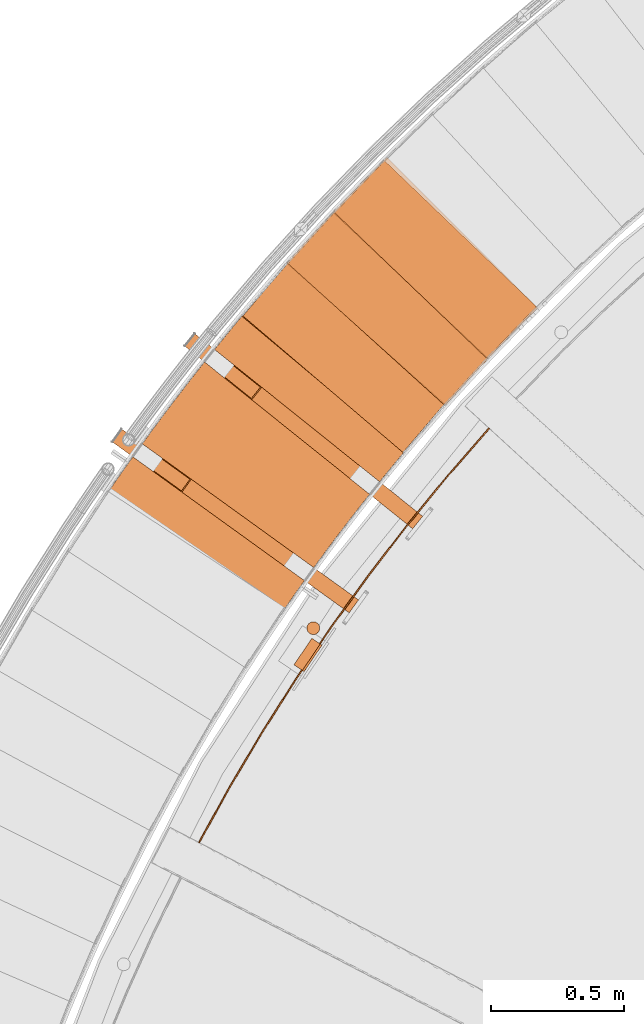
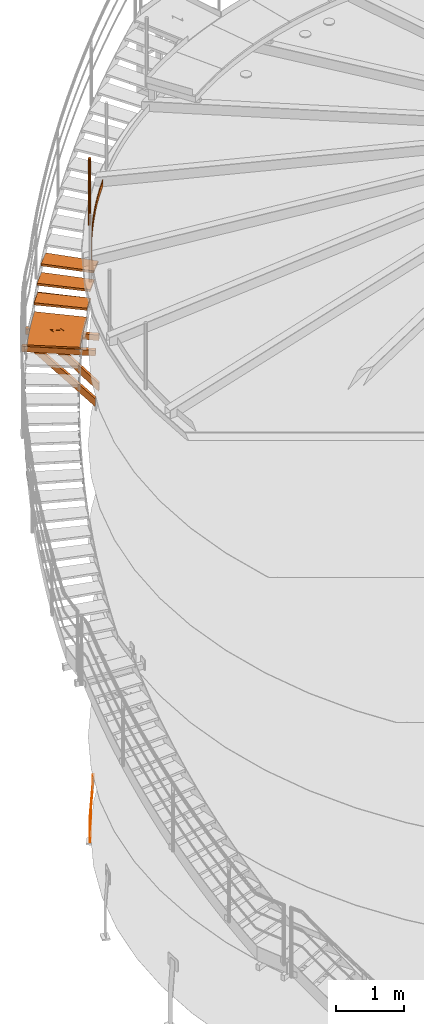
# One storey, part 31 of 126: 14 proxies.
"""IFC2X3 building model written with IfcOpenShell, lengths in millimetres."""

from ifc_helpers import new_model, si_unit, origin, origin_with_axes, place, context, project, spatial, faceted_brep, material, element, save


model = new_model("IFC2X3")

# Units and contexts
context_of_model_1 = context(None, 3, precision=0.1, world=origin())
context_of_model_2 = context(None, 3, precision=0.1, world=origin())
ifc_project = project(units=[si_unit("LENGTHUNIT", "METRE", prefix="MILLI"), si_unit("AREAUNIT", "SQUARE_METRE", prefix="CENTI"), si_unit("VOLUMEUNIT", "CUBIC_METRE", prefix="CENTI"), si_unit("MASSUNIT", "GRAM", prefix="KILO")], contexts=[context_of_model_1, context_of_model_2])

# Site, building, storey
site_placement = place(None, origin_with_axes())
site = spatial("IfcSite", under=ifc_project, at=site_placement, CompositionType="ELEMENT")
building_placement = place(site_placement, origin_with_axes())
building = spatial("IfcBuilding", under=site, at=building_placement, CompositionType="ELEMENT")
storey_placement = place(building_placement, origin_with_axes())
storey = spatial("IfcBuildingStorey", under=building, at=storey_placement, CompositionType="ELEMENT")

# Proxies
ifc_material_1 = material(Name="STAHL")
proxy_1_placement = place(storey_placement, origin_with_axes())
element("IfcBuildingElementProxy", 1, at=proxy_1_placement, inside=storey, material=ifc_material_1, Name="profile", context=context_of_model_2, shape_type="Brep", body=[
    faceted_brep([(1541.3, 12433.1, 651.1), (1539.9, 12431.0, 654.1), (1546.6, 12426.6, 654.1), (1548.0, 12428.6, 651.1), (1542.4, 12434.6, 647.7), (1549.0, 12430.2, 647.7), (1543.0, 12435.6, 643.9), (1549.6, 12431.1, 643.9), (1549.8, 12431.4, 640.0), (1549.8, 12431.4, 540.0), (1518.3, 12452.7, 0.0), (1518.3, 12452.7, -500.0), (1511.7, 12457.2, -500.0), (1511.7, 12457.2, 0.0), (1543.2, 12435.9, 540.0), (1543.2, 12435.9, 640.0), (1484.6, 12334.7, 651.1), (1486.0, 12336.8, 654.1), (1479.4, 12341.3, 654.1), (1478.0, 12339.2, 651.1), (1483.6, 12333.2, 647.7), (1477.0, 12337.7, 647.7), (1483.0, 12332.3, 643.9), (1476.3, 12336.7, 643.9), (1482.7, 12331.9, 540.0), (1482.7, 12331.9, 640.0), (1476.1, 12336.4, 640.0), (1476.1, 12336.4, 540.0), (1444.6, 12357.7, 0.0), (1444.6, 12357.7, -500.0), (1451.2, 12353.2, -500.0), (1451.2, 12353.2, 0.0), (1491.7, 12345.3, 659.6), (1493.9, 12348.5, 660.0), (1538.7, 12414.8, 660.0), (1540.8, 12418.1, 659.6), (1534.2, 12422.6, 659.6), (1532.0, 12419.3, 660.0), (1487.3, 12353.0, 660.0), (1485.1, 12349.8, 659.6), (1489.6, 12342.2, 658.5), (1483.0, 12346.7, 658.5), (1487.7, 12339.3, 656.6), (1481.1, 12343.8, 656.6), (1536.3, 12425.7, 658.5), (1542.9, 12421.2, 658.5), (1538.2, 12428.5, 656.6), (1544.9, 12424.1, 656.6)], [[[0, 1, 2, 3]], [[4, 0, 3, 5]], [[6, 4, 5, 7]], [[7, 8, 9, 10, 11, 12, 13, 14, 15, 6]], [[16, 17, 18, 19]], [[20, 16, 19, 21]], [[22, 20, 21, 23]], [[24, 25, 22, 23, 26, 27, 28, 29, 30, 31]], [[32, 33, 34, 35, 36, 37, 38, 39]], [[40, 32, 39, 41]], [[42, 40, 41, 43]], [[42, 43, 18, 17]], [[44, 36, 35, 45]], [[46, 44, 45, 47]], [[46, 47, 2, 1]], [[27, 26, 23, 21, 19, 18, 43, 41, 39, 38, 37, 36, 44, 46, 1, 0, 4, 6, 15, 14, 13, 12, 29, 28]], [[25, 24, 31, 30, 11, 10, 9, 8, 7, 5, 3, 2, 47, 45, 35, 34, 33, 32, 40, 42, 17, 16, 20, 22]], [[30, 29, 12, 11]]]),
])
proxy_2_placement = place(storey_placement, origin_with_axes())
element("IfcBuildingElementProxy", 2, at=proxy_2_placement, inside=storey, material=ifc_material_1, Name="profile", context=context_of_model_2, shape_type="Brep", body=[
    faceted_brep([(1541.0, 12499.6, 11706.0), (1541.0, 12499.6, 10506.0), (1539.3, 12505.2, 10506.0), (1539.3, 12505.2, 11706.0), (1536.3, 12510.1, 10506.0), (1536.3, 12510.1, 11706.0), (1532.1, 12514.2, 10506.0), (1532.1, 12514.2, 11706.0), (1527.2, 12517.2, 10506.0), (1527.2, 12517.2, 11706.0), (1521.6, 12519.0, 10506.0), (1521.6, 12519.0, 11706.0), (1515.8, 12519.3, 10506.0), (1515.8, 12519.3, 11706.0), (1510.1, 12518.2, 10506.0), (1510.1, 12518.2, 11706.0), (1504.8, 12515.8, 10506.0), (1504.8, 12515.8, 11706.0), (1500.2, 12512.2, 10506.0), (1500.2, 12512.2, 11706.0), (1496.6, 12507.6, 10506.0), (1496.6, 12507.6, 11706.0), (1494.2, 12502.3, 10506.0), (1494.2, 12502.3, 11706.0), (1493.2, 12496.6, 10506.0), (1493.2, 12496.6, 11706.0), (1493.6, 12490.8, 10506.0), (1493.6, 12490.8, 11706.0), (1495.3, 12485.2, 11706.0), (1495.3, 12485.2, 10506.0), (1498.3, 12480.3, 11706.0), (1498.3, 12480.3, 10506.0), (1502.5, 12476.2, 11706.0), (1502.5, 12476.2, 10506.0), (1507.4, 12473.2, 11706.0), (1507.4, 12473.2, 10506.0), (1513.0, 12471.4, 11706.0), (1513.0, 12471.4, 10506.0), (1518.8, 12471.1, 11706.0), (1518.8, 12471.1, 10506.0), (1524.5, 12472.2, 11706.0), (1524.5, 12472.2, 10506.0), (1529.9, 12474.6, 11706.0), (1529.9, 12474.6, 10506.0), (1534.4, 12478.2, 11706.0), (1534.4, 12478.2, 10506.0), (1538.0, 12482.8, 11706.0), (1538.0, 12482.8, 10506.0), (1540.4, 12488.1, 11706.0), (1540.4, 12488.1, 10506.0), (1541.4, 12493.8, 11706.0), (1541.4, 12493.8, 10506.0)], [[[0, 1, 2, 3]], [[3, 2, 4, 5]], [[5, 4, 6, 7]], [[7, 6, 8, 9]], [[9, 8, 10, 11]], [[11, 10, 12, 13]], [[13, 12, 14, 15]], [[15, 14, 16, 17]], [[17, 16, 18, 19]], [[19, 18, 20, 21]], [[21, 20, 22, 23]], [[23, 22, 24, 25]], [[25, 24, 26, 27]], [[28, 27, 26, 29]], [[30, 28, 29, 31]], [[32, 30, 31, 33]], [[34, 32, 33, 35]], [[36, 34, 35, 37]], [[38, 36, 37, 39]], [[40, 38, 39, 41]], [[42, 40, 41, 43]], [[44, 42, 43, 45]], [[46, 44, 45, 47]], [[48, 46, 47, 49]], [[50, 48, 49, 51]], [[0, 50, 51, 1]], [[38, 40, 42, 44, 46, 48, 50, 0, 3, 5, 7, 9, 11, 13, 15, 17, 19, 21, 23, 25, 27, 28, 30, 32, 34, 36]], [[39, 37, 35, 33, 31, 29, 26, 24, 22, 20, 18, 16, 14, 12, 10, 8, 6, 4, 2, 1, 51, 49, 47, 45, 43, 41]]]),
])
proxy_3_placement = place(storey_placement, origin_with_axes())
element("IfcBuildingElementProxy", 3, at=proxy_3_placement, inside=storey, material=ifc_material_1, Name="profile", context=context_of_model_2, shape_type="Brep", body=[
    faceted_brep([(1086.2, 11691.9, 10516.0), (1086.2, 11691.9, 10636.0), (1201.2, 11900.1, 10636.0), (1322.5, 12104.8, 10636.0), (1450.0, 12305.6, 10636.0), (1583.5, 12502.6, 10636.0), (1723.0, 12695.3, 10636.0), (1868.2, 12883.8, 10636.0), (2019.1, 13067.8, 10636.0), (2175.4, 13247.1, 10636.0), (2175.4, 13247.1, 10516.0), (2019.1, 13067.8, 10516.0), (1868.2, 12883.8, 10516.0), (1723.0, 12695.3, 10516.0), (1583.5, 12502.6, 10516.0), (1450.0, 12305.6, 10516.0), (1322.5, 12104.8, 10516.0), (1201.2, 11900.1, 10516.0), (1090.6, 11689.5, 10636.0), (1205.6, 11897.6, 10636.0), (1326.8, 12102.1, 10636.0), (1454.2, 12302.9, 10636.0), (1587.6, 12499.7, 10636.0), (1727.0, 12692.4, 10636.0), (1872.1, 12880.7, 10636.0), (2022.9, 13064.5, 10636.0), (2179.2, 13243.7, 10636.0), (1090.6, 11689.5, 10516.0), (1205.6, 11897.6, 10516.0), (1326.8, 12102.1, 10516.0), (1454.2, 12302.9, 10516.0), (1587.6, 12499.7, 10516.0), (1727.0, 12692.4, 10516.0), (1872.1, 12880.7, 10516.0), (2022.9, 13064.5, 10516.0), (2179.2, 13243.7, 10516.0)], [[[0, 1, 2, 3, 4, 5, 6, 7, 8, 9, 10, 11, 12, 13, 14, 15, 16, 17]], [[18, 19, 20, 21, 22, 23, 24, 25, 26, 9, 8, 7, 6, 5, 4, 3, 2, 1]], [[18, 27, 28, 29, 30, 31, 32, 33, 34, 35, 26, 25, 24, 23, 22, 21, 20, 19]], [[27, 0, 17, 16, 15, 14, 13, 12, 11, 10, 35, 34, 33, 32, 31, 30, 29, 28]], [[18, 1, 0, 27]], [[26, 35, 10, 9]]]),
])
ifc_material_2 = material(Name="HOLZ")
proxy_4_placement = place(storey_placement, origin_with_axes())
element("IfcBuildingElementProxy", 4, at=proxy_4_placement, inside=storey, material=ifc_material_2, context=context_of_model_2, shape_type="Brep", body=[
    faceted_brep([(1436.4084, 13886.589, 8487.1062), (1418.8783, 13866.953, 8487.1062), (1401.4068, 13847.264, 8487.1062), (1383.9943, 13827.523, 8487.1062), (1366.6407, 13807.73, 8487.1062), (1349.3464, 13787.885, 8487.1062), (1332.1113, 13767.989, 8487.1062), (1314.9357, 13748.042, 8487.1062), (1297.8198, 13728.043, 8487.1062), (1280.7636, 13707.993, 8487.1062), (1263.7674, 13687.893, 8487.1062), (1246.8312, 13667.742, 8487.1062), (1860.0256, 13153.94, 8487.1062), (1877.1435, 13174.3, 8487.1062), (1894.3289, 13194.604, 8487.1062), (1911.5816, 13214.85, 8487.1062), (1928.9013, 13235.04, 8487.1062), (1946.2879, 13255.171, 8487.1062), (1963.7413, 13275.245, 8487.1062), (1981.2611, 13295.261, 8487.1062), (1998.8473, 13315.218, 8487.1062), (2016.4996, 13335.117, 8487.1062), (2034.2178, 13354.958, 8487.1062), (1436.4084, 13886.589, 8447.1062), (2034.2178, 13354.958, 8447.1062), (2016.4996, 13335.117, 8447.1062), (1998.8473, 13315.218, 8447.1062), (1981.2611, 13295.261, 8447.1062), (1963.7413, 13275.245, 8447.1062), (1946.2879, 13255.171, 8447.1062), (1928.9013, 13235.04, 8447.1062), (1911.5816, 13214.85, 8447.1062), (1894.3289, 13194.604, 8447.1062), (1877.1435, 13174.3, 8447.1062), (1860.0256, 13153.94, 8447.1062), (1246.8312, 13667.742, 8447.1062), (1263.7674, 13687.893, 8447.1062), (1280.7636, 13707.993, 8447.1062), (1297.8198, 13728.043, 8447.1062), (1314.9357, 13748.042, 8447.1062), (1332.1113, 13767.989, 8447.1062), (1349.3464, 13787.885, 8447.1062), (1366.6407, 13807.73, 8447.1062), (1383.9943, 13827.523, 8447.1062), (1401.4068, 13847.264, 8447.1062), (1418.8783, 13866.953, 8447.1062)], [[[0, 1, 2, 3, 4, 5, 6, 7, 8, 9, 10, 11, 12, 13, 14, 15, 16, 17, 18, 19, 20, 21, 22]], [[23, 24, 25, 26, 27, 28, 29, 30, 31, 32, 33, 34, 35, 36, 37, 38, 39, 40, 41, 42, 43, 44, 45]], [[0, 23, 45, 1]], [[1, 45, 44, 2]], [[2, 44, 43, 3]], [[3, 43, 42, 4]], [[4, 42, 41, 5]], [[5, 41, 40, 6]], [[6, 40, 39, 7]], [[7, 39, 38, 8]], [[8, 38, 37, 9]], [[9, 37, 36, 10]], [[10, 36, 35, 11]], [[11, 35, 34, 12]], [[12, 34, 33, 13]], [[13, 33, 32, 14]], [[14, 32, 31, 15]], [[15, 31, 30, 16]], [[16, 30, 29, 17]], [[17, 29, 28, 18]], [[18, 28, 27, 19]], [[19, 27, 26, 20]], [[20, 26, 25, 21]], [[21, 25, 24, 22]], [[22, 24, 23, 0]]]),
])
proxy_5_placement = place(storey_placement, origin_with_axes())
element("IfcBuildingElementProxy", 5, at=proxy_5_placement, inside=storey, material=ifc_material_2, context=context_of_model_2, shape_type="Brep", body=[
    faceted_brep([(1612.3707, 14077.378, 8660.3125), (1594.2702, 14058.266, 8660.3125), (1576.2268, 14039.1, 8660.3125), (1558.2408, 14019.88, 8660.3125), (1540.3122, 14000.607, 8660.3125), (1522.4412, 13981.28, 8660.3125), (1504.628, 13961.9, 8660.3125), (1486.8727, 13942.466, 8660.3125), (1469.1756, 13922.98, 8660.3125), (1451.5366, 13903.441, 8660.3125), (1433.9561, 13883.85, 8660.3125), (1416.4342, 13864.206, 8660.3125), (2014.2398, 13332.577, 8660.3125), (2031.9496, 13352.425, 8660.3125), (2049.7252, 13372.214, 8660.3125), (2067.5663, 13391.944, 8660.3125), (2085.4728, 13411.615, 8660.3125), (2103.4444, 13431.226, 8660.3125), (2121.4811, 13450.778, 8660.3125), (2139.5825, 13470.269, 8660.3125), (2157.7484, 13489.7, 8660.3125), (2175.9788, 13509.071, 8660.3125), (2194.2733, 13528.382, 8660.3125), (1612.3707, 14077.378, 8620.3125), (2194.2733, 13528.382, 8620.3125), (2175.9788, 13509.071, 8620.3125), (2157.7484, 13489.7, 8620.3125), (2139.5825, 13470.269, 8620.3125), (2121.4811, 13450.778, 8620.3125), (2103.4444, 13431.226, 8620.3125), (2085.4728, 13411.615, 8620.3125), (2067.5663, 13391.944, 8620.3125), (2049.7252, 13372.214, 8620.3125), (2031.9496, 13352.425, 8620.3125), (2014.2398, 13332.577, 8620.3125), (1416.4342, 13864.206, 8620.3125), (1433.9561, 13883.85, 8620.3125), (1451.5366, 13903.441, 8620.3125), (1469.1756, 13922.98, 8620.3125), (1486.8727, 13942.466, 8620.3125), (1504.628, 13961.9, 8620.3125), (1522.4412, 13981.28, 8620.3125), (1540.3122, 14000.607, 8620.3125), (1558.2408, 14019.88, 8620.3125), (1576.2268, 14039.1, 8620.3125), (1594.2702, 14058.266, 8620.3125)], [[[0, 1, 2, 3, 4, 5, 6, 7, 8, 9, 10, 11, 12, 13, 14, 15, 16, 17, 18, 19, 20, 21, 22]], [[23, 24, 25, 26, 27, 28, 29, 30, 31, 32, 33, 34, 35, 36, 37, 38, 39, 40, 41, 42, 43, 44, 45]], [[0, 23, 45, 1]], [[1, 45, 44, 2]], [[2, 44, 43, 3]], [[3, 43, 42, 4]], [[4, 42, 41, 5]], [[5, 41, 40, 6]], [[6, 40, 39, 7]], [[7, 39, 38, 8]], [[8, 38, 37, 9]], [[9, 37, 36, 10]], [[10, 36, 35, 11]], [[11, 35, 34, 12]], [[12, 34, 33, 13]], [[13, 33, 32, 14]], [[14, 32, 31, 15]], [[15, 31, 30, 16]], [[16, 30, 29, 17]], [[17, 29, 28, 18]], [[18, 28, 27, 19]], [[19, 27, 26, 20]], [[20, 26, 25, 21]], [[21, 25, 24, 22]], [[22, 24, 23, 0]]]),
])
proxy_6_placement = place(storey_placement, origin_with_axes())
element("IfcBuildingElementProxy", 6, at=proxy_6_placement, inside=storey, material=ifc_material_2, context=context_of_model_2, shape_type="Brep", body=[
    faceted_brep([(1793.8724, 14262.906, 8833.5187), (1775.2172, 14244.334, 8833.5187), (1756.6175, 14225.708, 8833.5187), (1738.0735, 14207.026, 8833.5187), (1719.5854, 14188.288, 8833.5187), (1701.1533, 14169.496, 8833.5187), (1682.7774, 14150.648, 8833.5187), (1664.4578, 14131.746, 8833.5187), (1646.1948, 14112.789, 8833.5187), (1627.9884, 14093.778, 8833.5187), (1609.8389, 14074.712, 8833.5187), (1591.7464, 14055.592, 8833.5187), (2173.6452, 13506.599, 8833.5187), (2191.9316, 13525.917, 8833.5187), (2210.2819, 13545.174, 8833.5187), (2228.696, 13564.371, 8833.5187), (2247.1737, 13583.506, 8833.5187), (2265.7148, 13602.579, 8833.5187), (2284.3191, 13621.591, 8833.5187), (2302.9863, 13640.541, 8833.5187), (2321.7163, 13659.43, 8833.5187), (2340.5089, 13678.256, 8833.5187), (2359.3639, 13697.019, 8833.5187), (1793.8724, 14262.906, 8793.5187), (2359.3639, 13697.019, 8793.5187), (2340.5089, 13678.256, 8793.5187), (2321.7163, 13659.43, 8793.5187), (2302.9863, 13640.541, 8793.5187), (2284.3191, 13621.591, 8793.5187), (2265.7148, 13602.579, 8793.5187), (2247.1737, 13583.506, 8793.5187), (2228.696, 13564.371, 8793.5187), (2210.2819, 13545.174, 8793.5187), (2191.9316, 13525.917, 8793.5187), (2173.6452, 13506.599, 8793.5187), (1591.7464, 14055.592, 8793.5187), (1609.8389, 14074.712, 8793.5187), (1627.9884, 14093.778, 8793.5187), (1646.1948, 14112.789, 8793.5187), (1664.4578, 14131.746, 8793.5187), (1682.7774, 14150.648, 8793.5187), (1701.1533, 14169.496, 8793.5187), (1719.5854, 14188.288, 8793.5187), (1738.0735, 14207.026, 8793.5187), (1756.6175, 14225.708, 8793.5187), (1775.2172, 14244.334, 8793.5187)], [[[0, 1, 2, 3, 4, 5, 6, 7, 8, 9, 10, 11, 12, 13, 14, 15, 16, 17, 18, 19, 20, 21, 22]], [[23, 24, 25, 26, 27, 28, 29, 30, 31, 32, 33, 34, 35, 36, 37, 38, 39, 40, 41, 42, 43, 44, 45]], [[0, 23, 45, 1]], [[1, 45, 44, 2]], [[2, 44, 43, 3]], [[3, 43, 42, 4]], [[4, 42, 41, 5]], [[5, 41, 40, 6]], [[6, 40, 39, 7]], [[7, 39, 38, 8]], [[8, 38, 37, 9]], [[9, 37, 36, 10]], [[10, 36, 35, 11]], [[11, 35, 34, 12]], [[12, 34, 33, 13]], [[13, 33, 32, 14]], [[14, 32, 31, 15]], [[15, 31, 30, 16]], [[16, 30, 29, 17]], [[17, 29, 28, 18]], [[18, 28, 27, 19]], [[19, 27, 26, 20]], [[20, 26, 25, 21]], [[21, 25, 24, 22]], [[22, 24, 23, 0]]]),
])
ifc_material_3 = material(Name="S235JRG2")
proxy_7_placement = place(storey_placement, origin_with_axes())
element("IfcBuildingElementProxy", 7, at=proxy_7_placement, inside=storey, material=ifc_material_3, context=context_of_model_2, shape_type="Brep", body=[
    faceted_brep([(1252.8887, 13667.163, 8447.11), (1252.8887, 13667.163, 8487.11), (1428.0963, 13872.595, 8487.11), (1428.0963, 13872.595, 8447.11), (1853.9676, 13154.518, 8447.11), (2029.1751, 13359.95, 8447.11), (2029.1751, 13359.95, 8487.11), (1853.9676, 13154.518, 8487.11)], [[[0, 1, 2, 3]], [[4, 5, 6, 7]], [[0, 4, 7, 1]], [[1, 7, 6, 2]], [[2, 6, 5, 3]], [[3, 5, 4, 0]]]),
])
proxy_8_placement = place(storey_placement, origin_with_axes())
element("IfcBuildingElementProxy", 8, at=proxy_8_placement, inside=storey, material=ifc_material_3, context=context_of_model_2, shape_type="Brep", body=[
    faceted_brep([(1422.4715, 13863.448, 8620.27), (1422.4715, 13863.448, 8660.27), (1603.6497, 14063.634, 8660.27), (1603.6497, 14063.634, 8620.27), (2008.201, 13333.334, 8620.27), (2189.3793, 13533.52, 8620.27), (2189.3793, 13533.52, 8660.27), (2008.201, 13333.334, 8660.27)], [[[0, 1, 2, 3]], [[4, 5, 6, 7]], [[0, 4, 7, 1]], [[1, 7, 6, 2]], [[2, 6, 5, 3]], [[3, 5, 4, 0]]]),
])
proxy_9_placement = place(storey_placement, origin_with_axes())
element("IfcBuildingElementProxy", 9, at=proxy_9_placement, inside=storey, material=ifc_material_3, context=context_of_model_2, shape_type="Brep", body=[
    faceted_brep([(1597.7582, 14054.657, 8793.43), (1597.7582, 14054.657, 8833.43), (1784.7501, 14249.423, 8833.43), (1784.7501, 14249.423, 8793.43), (2167.6308, 13507.532, 8793.43), (2354.6227, 13702.299, 8793.43), (2354.6227, 13702.299, 8833.43), (2167.6308, 13507.532, 8833.43)], [[[0, 1, 2, 3]], [[4, 5, 6, 7]], [[0, 4, 7, 1]], [[1, 7, 6, 2]], [[2, 6, 5, 3]], [[3, 5, 4, 0]]]),
])
proxy_10_placement = place(storey_placement, origin_with_axes())
element("IfcBuildingElementProxy", 10, at=proxy_10_placement, inside=storey, material=ifc_material_3, context=context_of_model_2, shape_type="Brep", body=[
    faceted_brep([(764.1183, 13193.175, 8063.85), (764.1183, 13193.175, 8163.85), (799.2285, 13241.83, 8163.85), (799.2285, 13241.83, 8063.85), (765.8738, 13195.608, 8066.85), (797.4729, 13239.397, 8066.85), (797.4729, 13239.397, 8160.85), (765.8738, 13195.608, 8160.85), (1686.9102, 12601.26, 8063.85), (1651.8001, 12552.606, 8063.85), (1686.9102, 12601.26, 8163.85), (1651.8001, 12552.606, 8163.85), (1653.5556, 12555.039, 8160.85), (1653.5556, 12555.039, 8066.85), (1685.1547, 12598.828, 8160.85), (1685.1547, 12598.828, 8066.85)], [[[0, 1, 2, 3], [4, 5, 6, 7]], [[0, 3, 8, 9]], [[2, 10, 8, 3]], [[1, 11, 10, 2]], [[0, 9, 11, 1]], [[4, 7, 12, 13]], [[6, 14, 12, 7]], [[5, 15, 14, 6]], [[4, 13, 15, 5]], [[9, 8, 10, 11], [12, 14, 15, 13]]]),
])
proxy_11_placement = place(storey_placement, origin_with_axes())
element("IfcBuildingElementProxy", 11, at=proxy_11_placement, inside=storey, material=ifc_material_3, context=context_of_model_2, shape_type="Brep", body=[
    faceted_brep([(1035.8763, 13552.869, 8063.85), (1035.8763, 13552.869, 8163.85), (1073.4031, 13599.685, 8163.85), (1073.4031, 13599.685, 8063.85), (1037.7526, 13555.21, 8066.85), (1071.5268, 13597.344, 8066.85), (1071.5268, 13597.344, 8160.85), (1037.7526, 13555.21, 8160.85), (1927.5399, 12915.025, 8063.85), (1890.013, 12868.209, 8063.85), (1927.5399, 12915.025, 8163.85), (1890.013, 12868.209, 8163.85), (1891.8893, 12870.55, 8160.85), (1891.8893, 12870.55, 8066.85), (1925.6635, 12912.684, 8160.85), (1925.6635, 12912.684, 8066.85)], [[[0, 1, 2, 3], [4, 5, 6, 7]], [[0, 3, 8, 9]], [[2, 10, 8, 3]], [[1, 11, 10, 2]], [[0, 9, 11, 1]], [[4, 7, 12, 13]], [[6, 14, 12, 7]], [[5, 15, 14, 6]], [[4, 13, 15, 5]], [[9, 8, 10, 11], [12, 14, 15, 13]]]),
])
proxy_12_placement = place(storey_placement, origin_with_axes())
element("IfcBuildingElementProxy", 12, at=proxy_12_placement, inside=storey, material=ifc_material_3, context=context_of_model_2, shape_type="Brep", body=[
    faceted_brep([(1175.7698, 13440.733, 8063.85), (1213.2966, 13487.549, 8063.85), (1927.5399, 12915.025, 7148.4665), (1890.013, 12868.209, 7148.4665), (1323.643, 13399.097, 8063.85), (1927.5399, 12915.025, 7289.8879), (1286.1161, 13352.281, 8063.85), (1890.013, 12868.209, 7289.8879), (1180.9565, 13440.42, 8063.85), (1284.6821, 13357.276, 8063.85), (1891.8894, 12870.55, 7285.6452), (1891.8894, 12870.55, 7152.7091), (1318.4562, 13399.41, 8063.85), (1925.6635, 12912.684, 7285.6452), (1214.7306, 13482.554, 8063.85), (1925.6635, 12912.684, 7152.7091)], [[[0, 1, 2, 3]], [[1, 4, 5, 2]], [[4, 6, 7, 5]], [[0, 3, 7, 6]], [[8, 9, 10, 11]], [[9, 12, 13, 10]], [[12, 14, 15, 13]], [[8, 11, 15, 14]], [[1, 0, 6, 4], [8, 14, 12, 9]], [[3, 2, 5, 7], [10, 13, 15, 11]]]),
])
proxy_13_placement = place(storey_placement, origin_with_axes())
element("IfcBuildingElementProxy", 13, at=proxy_13_placement, inside=storey, material=ifc_material_3, Name="BLECH", context=context_of_model_2, shape_type="Brep", body=[
    faceted_brep([(740.2786, 12996.034, 8283.85), (745.1764, 13003.163, 8283.85), (755.0003, 13017.402, 8283.85), (764.8521, 13031.622, 8283.85), (774.7317, 13045.822, 8283.85), (784.6393, 13060.003, 8283.85), (794.5745, 13074.165, 8283.85), (804.5375, 13088.307, 8283.85), (814.5285, 13102.429, 8283.85), (824.5469, 13116.532, 8283.85), (834.593, 13130.615, 8283.85), (844.6668, 13144.679, 8283.85), (854.768, 13158.722, 8283.85), (864.897, 13172.746, 8283.85), (875.0534, 13186.75, 8283.85), (885.2373, 13200.733, 8283.85), (895.4486, 13214.697, 8283.85), (905.6872, 13228.641, 8283.85), (915.9534, 13242.565, 8283.85), (926.2467, 13256.468, 8283.85), (936.5674, 13270.351, 8283.85), (946.9153, 13284.214, 8283.85), (957.2903, 13298.057, 8283.85), (967.6925, 13311.879, 8283.85), (978.1218, 13325.681, 8283.85), (988.578, 13339.462, 8283.85), (999.0616, 13353.223, 8283.85), (1009.5718, 13366.963, 8283.85), (1020.1091, 13380.682, 8283.85), (1030.6733, 13394.381, 8283.85), (1041.2644, 13408.059, 8283.85), (1051.8823, 13421.716, 8283.85), (1062.5271, 13435.353, 8283.85), (1073.1985, 13448.968, 8283.85), (1083.8967, 13462.562, 8283.85), (1094.6215, 13476.136, 8283.85), (1105.3728, 13489.688, 8283.85), (1116.151, 13503.219, 8283.85), (1126.9555, 13516.729, 8283.85), (1137.7865, 13530.218, 8283.85), (1148.6441, 13543.686, 8283.85), (1159.528, 13557.132, 8283.85), (1170.4381, 13570.557, 8283.85), (1181.3749, 13583.96, 8283.85), (1192.3375, 13597.342, 8283.85), (1203.3268, 13610.702, 8283.85), (1214.3423, 13624.041, 8283.85), (1225.3837, 13637.358, 8283.85), (1236.4512, 13650.653, 8283.85), (1247.5448, 13663.927, 8283.85), (1258.6645, 13677.179, 8283.85), (1264.2376, 13683.794, 8283.85), (1868.3535, 13168.51, 8283.85), (1863.3174, 13162.525, 8283.85), (1853.2689, 13150.535, 8283.85), (1843.2435, 13138.526, 8283.85), (1833.2418, 13126.497, 8283.85), (1823.2633, 13114.449, 8283.85), (1813.3087, 13102.382, 8283.85), (1803.3773, 13090.294, 8283.85), (1793.4697, 13078.188, 8283.85), (1783.5857, 13066.062, 8283.85), (1773.7255, 13053.917, 8283.85), (1763.8887, 13041.753, 8283.85), (1754.0759, 13029.57, 8283.85), (1744.2868, 13017.368, 8283.85), (1734.5215, 13005.146, 8283.85), (1724.7801, 12992.906, 8283.85), (1715.0626, 12980.646, 8283.85), (1705.369, 12968.368, 8283.85), (1695.6994, 12956.07, 8283.85), (1686.0536, 12943.754, 8283.85), (1676.4321, 12931.419, 8283.85), (1666.8346, 12919.066, 8283.85), (1657.2612, 12906.693, 8283.85), (1647.712, 12894.302, 8283.85), (1638.1869, 12881.892, 8283.85), (1628.6861, 12869.464, 8283.85), (1619.2096, 12857.018, 8283.85), (1609.7574, 12844.553, 8283.85), (1600.3295, 12832.069, 8283.85), (1590.9259, 12819.567, 8283.85), (1581.5467, 12807.047, 8283.85), (1572.192, 12794.508, 8283.85), (1562.8617, 12781.951, 8283.85), (1553.556, 12769.377, 8283.85), (1544.2748, 12756.784, 8283.85), (1535.0183, 12744.172, 8283.85), (1525.7861, 12731.543, 8283.85), (1516.5787, 12718.896, 8283.85), (1507.3963, 12706.231, 8283.85), (1498.2384, 12693.548, 8283.85), (1489.1051, 12680.847, 8283.85), (1479.9967, 12668.129, 8283.85), (1470.9132, 12655.392, 8283.85), (1461.8546, 12642.638, 8283.85), (1452.8206, 12629.866, 8283.85), (1443.8117, 12617.077, 8283.85), (1434.828, 12604.27, 8283.85), (1425.8688, 12591.446, 8283.85), (1416.9351, 12578.604, 8283.85), (1408.0263, 12565.745, 8283.85), (1399.1427, 12552.869, 8283.85), (1394.7133, 12546.422, 8283.85), (740.2786, 12996.034, 8313.85), (1394.7133, 12546.422, 8313.85), (1399.1427, 12552.869, 8313.85), (1408.0263, 12565.745, 8313.85), (1416.9351, 12578.604, 8313.85), (1425.8688, 12591.446, 8313.85), (1434.828, 12604.27, 8313.85), (1443.8117, 12617.077, 8313.85), (1452.8206, 12629.866, 8313.85), (1461.8546, 12642.638, 8313.85), (1470.9132, 12655.392, 8313.85), (1479.9967, 12668.129, 8313.85), (1489.1051, 12680.847, 8313.85), (1498.2384, 12693.548, 8313.85), (1507.3963, 12706.231, 8313.85), (1516.5787, 12718.896, 8313.85), (1525.7861, 12731.543, 8313.85), (1535.0183, 12744.172, 8313.85), (1544.2748, 12756.784, 8313.85), (1553.556, 12769.377, 8313.85), (1562.8617, 12781.951, 8313.85), (1572.192, 12794.508, 8313.85), (1581.5467, 12807.047, 8313.85), (1590.9259, 12819.567, 8313.85), (1600.3295, 12832.069, 8313.85), (1609.7574, 12844.553, 8313.85), (1619.2096, 12857.018, 8313.85), (1628.6861, 12869.464, 8313.85), (1638.1869, 12881.892, 8313.85), (1647.712, 12894.302, 8313.85), (1657.2612, 12906.693, 8313.85), (1666.8346, 12919.066, 8313.85), (1676.4321, 12931.419, 8313.85), (1686.0536, 12943.754, 8313.85), (1695.6994, 12956.07, 8313.85), (1705.369, 12968.368, 8313.85), (1715.0626, 12980.646, 8313.85), (1724.7801, 12992.906, 8313.85), (1734.5215, 13005.146, 8313.85), (1744.2868, 13017.368, 8313.85), (1754.0759, 13029.57, 8313.85), (1763.8887, 13041.753, 8313.85), (1773.7255, 13053.917, 8313.85), (1783.5857, 13066.062, 8313.85), (1793.4697, 13078.188, 8313.85), (1803.3773, 13090.294, 8313.85), (1813.3087, 13102.382, 8313.85), (1823.2633, 13114.449, 8313.85), (1833.2418, 13126.497, 8313.85), (1843.2435, 13138.526, 8313.85), (1853.2689, 13150.535, 8313.85), (1863.3174, 13162.525, 8313.85), (1868.3535, 13168.51, 8313.85), (1264.2376, 13683.794, 8313.85), (1258.6645, 13677.179, 8313.85), (1247.5448, 13663.927, 8313.85), (1236.4512, 13650.653, 8313.85), (1225.3837, 13637.358, 8313.85), (1214.3423, 13624.041, 8313.85), (1203.3268, 13610.702, 8313.85), (1192.3375, 13597.342, 8313.85), (1181.3749, 13583.96, 8313.85), (1170.4381, 13570.557, 8313.85), (1159.528, 13557.132, 8313.85), (1148.6441, 13543.686, 8313.85), (1137.7865, 13530.218, 8313.85), (1126.9555, 13516.729, 8313.85), (1116.151, 13503.219, 8313.85), (1105.3728, 13489.688, 8313.85), (1094.6215, 13476.136, 8313.85), (1083.8967, 13462.562, 8313.85), (1073.1985, 13448.968, 8313.85), (1062.5271, 13435.353, 8313.85), (1051.8823, 13421.716, 8313.85), (1041.2644, 13408.059, 8313.85), (1030.6733, 13394.381, 8313.85), (1020.1091, 13380.682, 8313.85), (1009.5718, 13366.963, 8313.85), (999.0616, 13353.223, 8313.85), (988.578, 13339.462, 8313.85), (978.1218, 13325.681, 8313.85), (967.6925, 13311.879, 8313.85), (957.2903, 13298.057, 8313.85), (946.9153, 13284.214, 8313.85), (936.5674, 13270.351, 8313.85), (926.2467, 13256.468, 8313.85), (915.9534, 13242.565, 8313.85), (905.6872, 13228.641, 8313.85), (895.4486, 13214.697, 8313.85), (885.2373, 13200.733, 8313.85), (875.0534, 13186.75, 8313.85), (864.897, 13172.746, 8313.85), (854.768, 13158.722, 8313.85), (844.6668, 13144.679, 8313.85), (834.593, 13130.615, 8313.85), (824.5469, 13116.532, 8313.85), (814.5285, 13102.429, 8313.85), (804.5375, 13088.307, 8313.85), (794.5745, 13074.165, 8313.85), (784.6393, 13060.003, 8313.85), (774.7317, 13045.822, 8313.85), (764.8521, 13031.622, 8313.85), (755.0003, 13017.402, 8313.85), (745.1764, 13003.163, 8313.85), (1376.5204, 13112.251, 8313.85), (1383.403, 13113.528, 8313.85), (1398.1378, 13034.103, 8313.85), (1239.0106, 13155.258, 8313.85), (1250.4368, 13093.668, 8313.85), (1243.5543, 13092.391, 8313.85), (1228.8195, 13171.816, 8313.85), (1387.9467, 13050.661, 8313.85), (1376.5204, 13112.251, 8308.85), (1383.403, 13113.528, 8308.85), (1387.9467, 13050.661, 8308.85), (1398.1378, 13034.103, 8308.85), (1228.8195, 13171.816, 8308.85), (1239.0106, 13155.258, 8308.85), (1243.5543, 13092.391, 8308.85), (1250.4368, 13093.668, 8308.85)], [[[0, 1, 2, 3, 4, 5, 6, 7, 8, 9, 10, 11, 12, 13, 14, 15, 16, 17, 18, 19, 20, 21, 22, 23, 24, 25, 26, 27, 28, 29, 30, 31, 32, 33, 34, 35, 36, 37, 38, 39, 40, 41, 42, 43, 44, 45, 46, 47, 48, 49, 50, 51, 52, 53, 54, 55, 56, 57, 58, 59, 60, 61, 62, 63, 64, 65, 66, 67, 68, 69, 70, 71, 72, 73, 74, 75, 76, 77, 78, 79, 80, 81, 82, 83, 84, 85, 86, 87, 88, 89, 90, 91, 92, 93, 94, 95, 96, 97, 98, 99, 100, 101, 102, 103]], [[104, 105, 106, 107, 108, 109, 110, 111, 112, 113, 114, 115, 116, 117, 118, 119, 120, 121, 122, 123, 124, 125, 126, 127, 128, 129, 130, 131, 132, 133, 134, 135, 136, 137, 138, 139, 140, 141, 142, 143, 144, 145, 146, 147, 148, 149, 150, 151, 152, 153, 154, 155, 156, 157, 158, 159, 160, 161, 162, 163, 164, 165, 166, 167, 168, 169, 170, 171, 172, 173, 174, 175, 176, 177, 178, 179, 180, 181, 182, 183, 184, 185, 186, 187, 188, 189, 190, 191, 192, 193, 194, 195, 196, 197, 198, 199, 200, 201, 202, 203, 204, 205, 206, 207], [208, 209, 210, 211, 212, 213, 214, 215]], [[0, 104, 207, 1]], [[1, 207, 206, 2]], [[2, 206, 205, 3]], [[3, 205, 204, 4]], [[4, 204, 203, 5]], [[5, 203, 202, 6]], [[6, 202, 201, 7]], [[7, 201, 200, 8]], [[8, 200, 199, 9]], [[9, 199, 198, 10]], [[10, 198, 197, 11]], [[11, 197, 196, 12]], [[12, 196, 195, 13]], [[13, 195, 194, 14]], [[14, 194, 193, 15]], [[15, 193, 192, 16]], [[16, 192, 191, 17]], [[17, 191, 190, 18]], [[18, 190, 189, 19]], [[19, 189, 188, 20]], [[20, 188, 187, 21]], [[21, 187, 186, 22]], [[22, 186, 185, 23]], [[23, 185, 184, 24]], [[24, 184, 183, 25]], [[25, 183, 182, 26]], [[26, 182, 181, 27]], [[27, 181, 180, 28]], [[28, 180, 179, 29]], [[29, 179, 178, 30]], [[30, 178, 177, 31]], [[31, 177, 176, 32]], [[32, 176, 175, 33]], [[33, 175, 174, 34]], [[34, 174, 173, 35]], [[35, 173, 172, 36]], [[36, 172, 171, 37]], [[37, 171, 170, 38]], [[38, 170, 169, 39]], [[39, 169, 168, 40]], [[40, 168, 167, 41]], [[41, 167, 166, 42]], [[42, 166, 165, 43]], [[43, 165, 164, 44]], [[44, 164, 163, 45]], [[45, 163, 162, 46]], [[46, 162, 161, 47]], [[47, 161, 160, 48]], [[48, 160, 159, 49]], [[49, 159, 158, 50]], [[50, 158, 157, 51]], [[51, 157, 156, 52]], [[52, 156, 155, 53]], [[53, 155, 154, 54]], [[54, 154, 153, 55]], [[55, 153, 152, 56]], [[56, 152, 151, 57]], [[57, 151, 150, 58]], [[58, 150, 149, 59]], [[59, 149, 148, 60]], [[60, 148, 147, 61]], [[61, 147, 146, 62]], [[62, 146, 145, 63]], [[63, 145, 144, 64]], [[64, 144, 143, 65]], [[65, 143, 142, 66]], [[66, 142, 141, 67]], [[67, 141, 140, 68]], [[68, 140, 139, 69]], [[69, 139, 138, 70]], [[70, 138, 137, 71]], [[71, 137, 136, 72]], [[72, 136, 135, 73]], [[73, 135, 134, 74]], [[74, 134, 133, 75]], [[75, 133, 132, 76]], [[76, 132, 131, 77]], [[77, 131, 130, 78]], [[78, 130, 129, 79]], [[79, 129, 128, 80]], [[80, 128, 127, 81]], [[81, 127, 126, 82]], [[82, 126, 125, 83]], [[83, 125, 124, 84]], [[84, 124, 123, 85]], [[85, 123, 122, 86]], [[86, 122, 121, 87]], [[87, 121, 120, 88]], [[88, 120, 119, 89]], [[89, 119, 118, 90]], [[90, 118, 117, 91]], [[91, 117, 116, 92]], [[92, 116, 115, 93]], [[93, 115, 114, 94]], [[94, 114, 113, 95]], [[95, 113, 112, 96]], [[96, 112, 111, 97]], [[97, 111, 110, 98]], [[98, 110, 109, 99]], [[99, 109, 108, 100]], [[100, 108, 107, 101]], [[101, 107, 106, 102]], [[102, 106, 105, 103]], [[0, 103, 105, 104]], [[208, 216, 217, 209]], [[216, 218, 219, 217]], [[208, 215, 218, 216]], [[209, 217, 219, 210]], [[219, 218, 220, 221]], [[214, 220, 218, 215]], [[210, 219, 221, 211]], [[221, 220, 222, 223]], [[213, 222, 220, 214]], [[211, 221, 223, 212]], [[212, 223, 222, 213]]]),
])
proxy_14_placement = place(storey_placement, origin_with_axes())
element("IfcBuildingElementProxy", 14, at=proxy_14_placement, inside=storey, material=ifc_material_3, context=context_of_model_2, shape_type="Brep", body=[
    faceted_brep([(909.5059, 13088.261, 8063.85), (944.6161, 13136.915, 8063.85), (1686.9103, 12601.26, 7148.4665), (1651.8001, 12552.606, 7148.4665), (1059.2962, 13054.16, 8063.85), (1686.9103, 12601.26, 7289.8879), (1024.186, 13005.505, 8063.85), (1651.8001, 12552.606, 7289.8879), (914.7018, 13088.211, 8063.85), (1022.5011, 13010.421, 8063.85), (1653.5556, 12555.039, 7285.6452), (1653.5556, 12555.039, 7152.7091), (1054.1002, 13054.21, 8063.85), (1685.1548, 12598.828, 7285.6452), (946.301, 13132.0, 8063.85), (1685.1548, 12598.828, 7152.7091)], [[[0, 1, 2, 3]], [[1, 4, 5, 2]], [[4, 6, 7, 5]], [[0, 3, 7, 6]], [[8, 9, 10, 11]], [[9, 12, 13, 10]], [[12, 14, 15, 13]], [[8, 11, 15, 14]], [[1, 0, 6, 4], [8, 14, 12, 9]], [[3, 2, 5, 7], [10, 13, 15, 11]]]),
])

save(model, "model.ifc")
